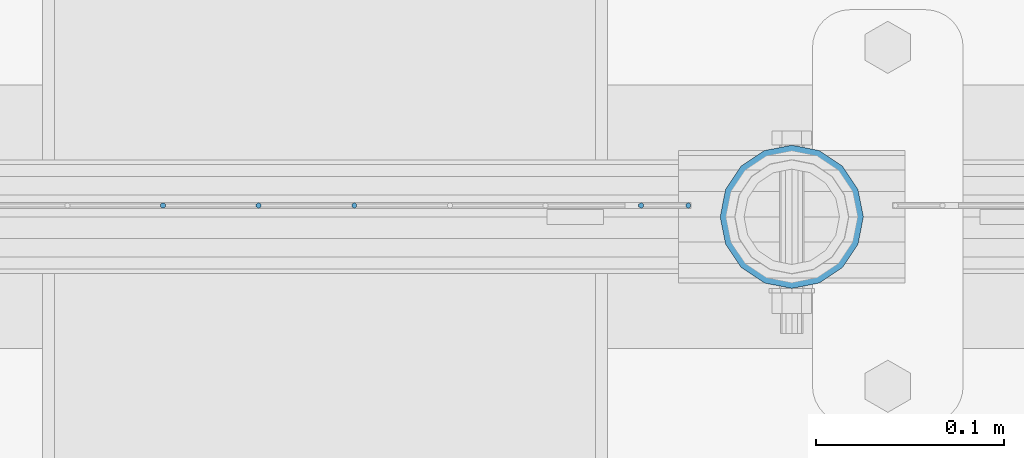
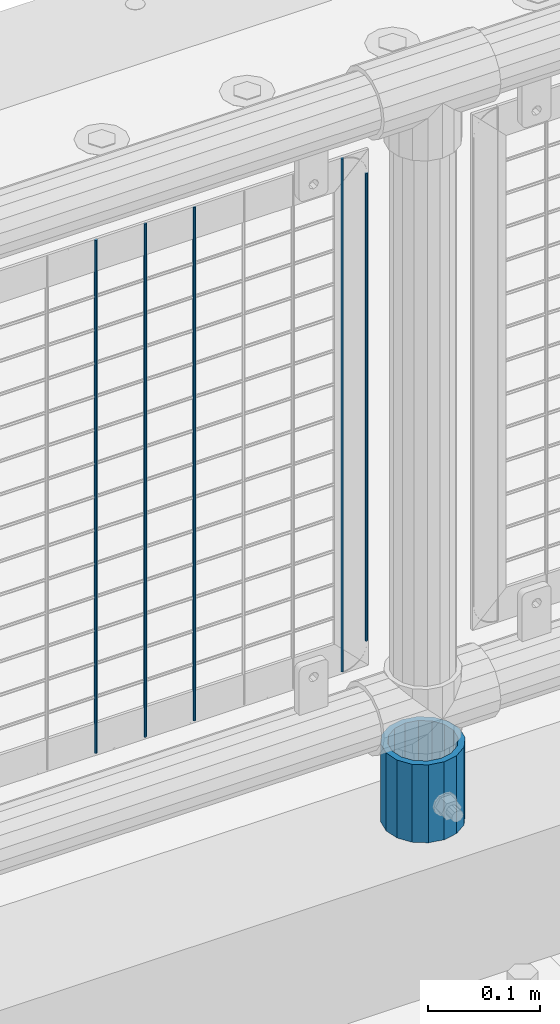
# One storey, part 98 of 242: 6 columns.
"""IFC2X3 building model written with IfcOpenShell, lengths in millimetres."""

from ifc_helpers import new_model, si_unit, frame, origin_with_axes, place, context, subcontext, project, spatial, faceted_brep, material, type_object, element, save


model = new_model("IFC2X3")

# Units and contexts
model_context = context("Model", 3, precision=1e-05, world=origin_with_axes())
body_context = subcontext(model_context, "Body", "Model", "MODEL_VIEW")
ifc_project = project(units=[si_unit("LENGTHUNIT", "METRE", prefix="MILLI"), si_unit("AREAUNIT", "SQUARE_METRE"), si_unit("VOLUMEUNIT", "CUBIC_METRE"), si_unit("MASSUNIT", "GRAM", prefix="KILO"), si_unit("TIMEUNIT", "SECOND"), si_unit("PLANEANGLEUNIT", "RADIAN"), si_unit("SOLIDANGLEUNIT", "STERADIAN"), si_unit("THERMODYNAMICTEMPERATUREUNIT", "DEGREE_CELSIUS"), si_unit("LUMINOUSINTENSITYUNIT", "LUMEN")], contexts=[model_context])

# Site, building, storey
site_placement = place(None, origin_with_axes())
site = spatial("IfcSite", under=ifc_project, at=site_placement, CompositionType="ELEMENT")
building_placement = place(site_placement, origin_with_axes())
building = spatial("IfcBuilding", under=site, at=building_placement, Name="Standard", CompositionType="ELEMENT")
storey_placement = place(building_placement, origin_with_axes())
storey = spatial("IfcBuildingStorey", under=building, at=storey_placement, Name="Undefined", CompositionType="ELEMENT", Elevation=0.0)

# Columns
ifc_material_1 = material(Name="Misc_Undefined")
column_type_1 = type_object("IfcColumnType", Name="D3", PredefinedType="NOTDEFINED")
for number, where, z_axis, x_axis in (
    (1, (-27364.382, -19329.5, 353.02), (-1.0, 0.0, 0.0), (0.0, 0.0, 1.0)),
    (2, (-27415.175, -19329.5, 353.02), (-1.0, 0.0, 0.0), (0.0, 0.0, 1.0)),
    (3, (-27465.968, -19329.5, 353.02), (-1.0, 0.0, 0.0), (0.0, 0.0, 1.0)),
    (4, (-27212.003, -19329.5, 353.02), (-1.0, 0.0, 0.0), (0.0, 0.0, 1.0)),
):
    element("IfcColumn", number, at=place(storey_placement, frame(where, z_axis=z_axis, x_axis=x_axis)), inside=storey, type_object=column_type_1, material=ifc_material_1, ObjectType="D3", context=body_context, shape_type="Brep", body=[
        faceted_brep([(0.0, -1.50000000000364, 0.0), (-3.63797880709171e-12, -0.750000000003638, -1.29903810567669), (560.0, -0.75, -1.29903810567703), (560.0, -1.5, 0.0), (0.0, 0.749999999996362, -1.29903810567669), (560.0, 0.75, -1.29903810567703), (-3.63797880709171e-12, 1.49999999999636, 0.0), (560.0, 1.5, 0.0), (0.0, 0.749999999996362, 1.29903810567669), (560.0, 0.75, 1.29903810567703), (-3.63797880709171e-12, -0.750000000003638, 1.29903810567669), (560.0, -0.75, 1.29903810567703)], [[[0, 1, 2, 3]], [[1, 4, 5, 2]], [[4, 6, 7, 5]], [[6, 8, 9, 7]], [[8, 10, 11, 9]], [[10, 0, 3, 11]], [[5, 7, 9, 11, 3, 2]], [[10, 8, 6, 4, 1, 0]]]),
    ])
column_1_placement = place(storey_placement, frame((-27187.0, -19329.5, 378.02), z_axis=(-1.0, 0.0, 0.0), x_axis=(0.0, 0.0, 1.0)))
element("IfcColumn", 5, at=column_1_placement, inside=storey, type_object=column_type_1, material=ifc_material_1, ObjectType="D3", context=body_context, shape_type="Brep", body=[
    faceted_brep([(0.0, -1.50000000000364, 0.0), (-3.63797880709171e-12, -0.750000000003638, -1.29903810567669), (510.0, -0.75, -1.29903810567703), (510.0, -1.5, 0.0), (0.0, 0.749999999996362, -1.29903810567669), (510.0, 0.75, -1.29903810567703), (-3.63797880709171e-12, 1.49999999999636, 0.0), (510.0, 1.5, 0.0), (0.0, 0.749999999996362, 1.29903810567669), (510.0, 0.75, 1.29903810567703), (-3.63797880709171e-12, -0.750000000003638, 1.29903810567669), (510.0, -0.75, 1.29903810567703)], [[[0, 1, 2, 3]], [[1, 4, 5, 2]], [[4, 6, 7, 5]], [[6, 8, 9, 7]], [[8, 10, 11, 9]], [[10, 0, 3, 11]], [[5, 7, 9, 11, 3, 2]], [[10, 8, 6, 4, 1, 0]]]),
])
ifc_material_2 = material()
column_type_2 = type_object("IfcColumnType", PredefinedType="NOTDEFINED")
column_2_placement = place(storey_placement, frame((-27132.0, -19335.5, 168.02), z_axis=(0.0, 1.0, 0.0), x_axis=(0.0, 0.0, 1.0)))
element("IfcColumn", 6, at=column_2_placement, inside=storey, type_object=column_type_2, material=ifc_material_2, context=body_context, shape_type="Brep", body=[
    faceted_brep([(0.0, -31.75, 0.0), (0.0, -29.3331751572332, 12.1501989775934), (85.0, -29.3331751572332, 12.1501989775934), (85.0, -31.75, 0.0), (0.0, -22.4506403026717, 22.4506403026717), (85.0, -22.4506403026717, 22.4506403026717), (0.0, -12.1501989775934, 29.3331751572332), (85.0, -12.1501989775934, 29.3331751572332), (0.0, 0.0, 31.75), (85.0, 0.0, 31.75), (0.0, 12.1501989775934, 29.3331751572332), (85.0, 12.1501989775934, 29.3331751572332), (0.0, 22.4506403026717, 22.4506403026717), (85.0, 22.4506403026717, 22.4506403026717), (0.0, 29.3331751572332, 12.1501989775934), (85.0, 29.3331751572332, 12.1501989775934), (0.0, 31.75, 0.0), (85.0, 31.75, 0.0), (0.0, 29.3331751572332, -12.1501989775934), (85.0, 29.3331751572332, -12.1501989775934), (0.0, 22.4506403026717, -22.4506403026717), (85.0, 22.4506403026717, -22.4506403026717), (0.0, 12.1501989775934, -29.3331751572332), (85.0, 12.1501989775934, -29.3331751572332), (0.0, 0.0, -31.75), (85.0, 0.0, -31.75), (0.0, -12.1501989775934, -29.3331751572332), (85.0, -12.1501989775934, -29.3331751572332), (0.0, -22.4506403026717, -22.4506403026717), (85.0, -22.4506403026717, -22.4506403026717), (0.0, -29.3331751572332, -12.1501989775934), (85.0, -29.3331751572332, -12.1501989775934), (0.0, -38.0499999999993, 0.0), (0.0, -35.1536162120537, -14.5611046014928), (85.0, -35.1536162120537, -14.5611046014928), (85.0, -38.0499999999993, 0.0), (0.0, -26.9054130241493, -26.9054130241493), (85.0, -26.9054130241493, -26.9054130241493), (0.0, -14.5611046014928, -35.1536162120537), (85.0, -14.5611046014928, -35.1536162120537), (0.0, 0.0, -38.0499999999993), (85.0, 0.0, -38.0499999999993), (0.0, 14.5611046014928, -35.1536162120537), (85.0, 14.5611046014928, -35.1536162120537), (0.0, 26.9054130241493, -26.9054130241493), (85.0, 26.9054130241493, -26.9054130241493), (0.0, 35.1536162120537, -14.5611046014928), (85.0, 35.1536162120537, -14.5611046014928), (0.0, 38.0499999999993, 0.0), (85.0, 38.0499999999993, 0.0), (0.0, 35.1536162120537, 14.5611046014928), (85.0, 35.1536162120537, 14.5611046014928), (0.0, 26.9054130241493, 26.9054130241493), (85.0, 26.9054130241493, 26.9054130241493), (0.0, 14.5611046014928, 35.1536162120537), (85.0, 14.5611046014928, 35.1536162120537), (0.0, 0.0, 38.0499999999993), (85.0, 0.0, 38.0499999999993), (0.0, -14.5611046014928, 35.1536162120537), (85.0, -14.5611046014928, 35.1536162120537), (0.0, -26.9054130241493, 26.9054130241493), (85.0, -26.9054130241493, 26.9054130241493), (0.0, -35.1536162120537, 14.5611046014928), (85.0, -35.1536162120537, 14.5611046014928)], [[[0, 1, 2, 3]], [[1, 4, 5, 2]], [[4, 6, 7, 5]], [[6, 8, 9, 7]], [[8, 10, 11, 9]], [[10, 12, 13, 11]], [[12, 14, 15, 13]], [[14, 16, 17, 15]], [[16, 18, 19, 17]], [[18, 20, 21, 19]], [[20, 22, 23, 21]], [[22, 24, 25, 23]], [[24, 26, 27, 25]], [[26, 28, 29, 27]], [[28, 30, 31, 29]], [[30, 0, 3, 31]], [[32, 33, 34, 35]], [[33, 36, 37, 34]], [[36, 38, 39, 37]], [[38, 40, 41, 39]], [[40, 42, 43, 41]], [[42, 44, 45, 43]], [[44, 46, 47, 45]], [[46, 48, 49, 47]], [[48, 50, 51, 49]], [[50, 52, 53, 51]], [[52, 54, 55, 53]], [[54, 56, 57, 55]], [[56, 58, 59, 57]], [[58, 60, 61, 59]], [[60, 62, 63, 61]], [[62, 32, 35, 63]], [[37, 39, 41, 43, 45, 47, 49, 51, 53, 55, 57, 59, 61, 63, 35, 34], [5, 7, 9, 11, 13, 15, 17, 19, 21, 23, 25, 27, 29, 31, 3, 2]], [[62, 60, 58, 56, 54, 52, 50, 48, 46, 44, 42, 40, 38, 36, 33, 32], [30, 28, 26, 24, 22, 20, 18, 16, 14, 12, 10, 8, 6, 4, 1, 0]]]),
])

save(model, "model.ifc")
